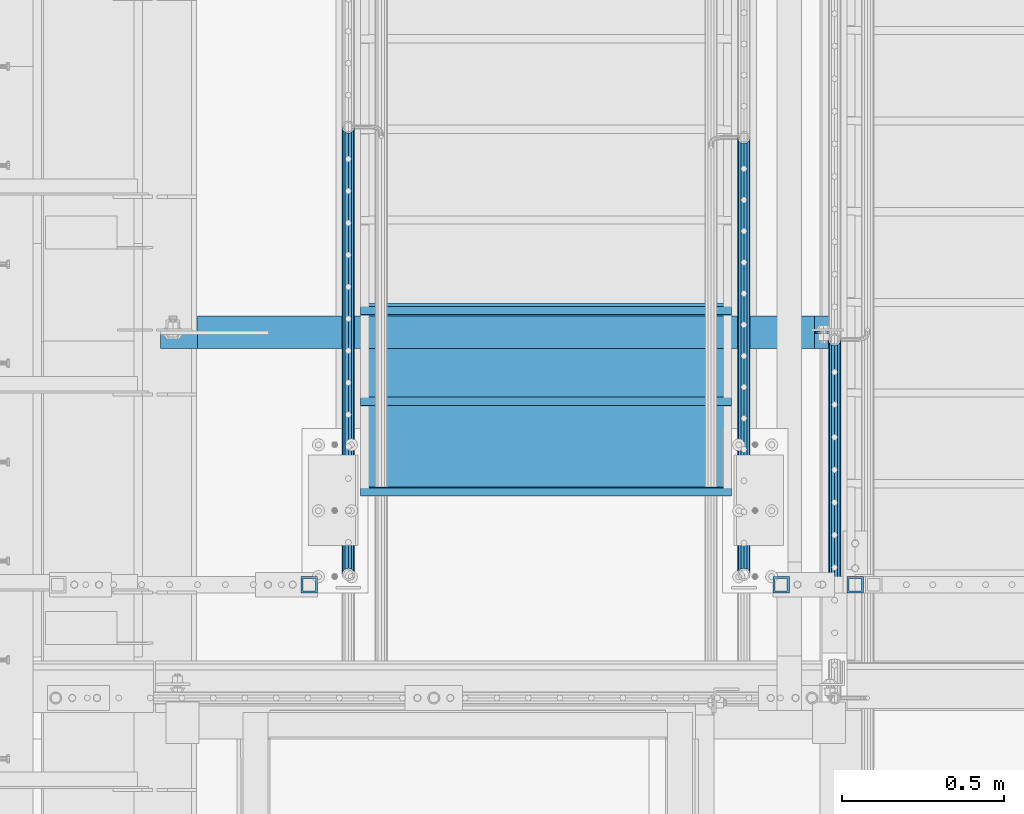
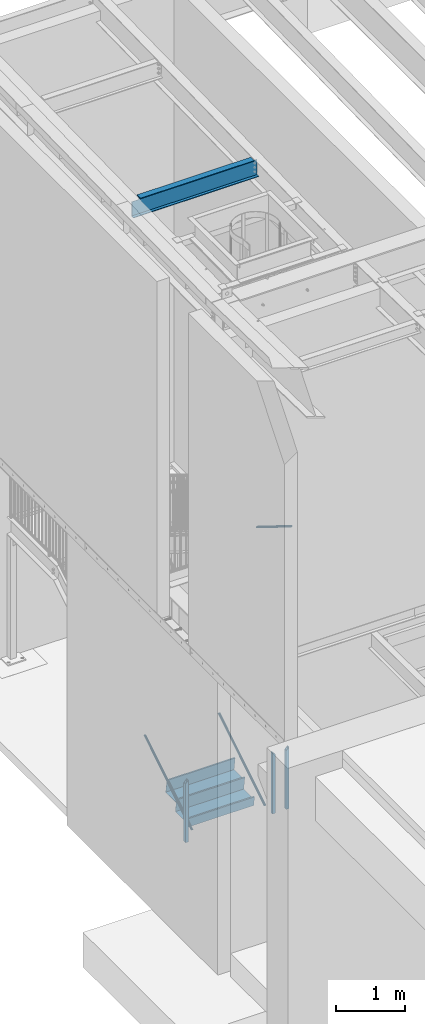
# One storey, part 1086 of 1763: 7 beams, 3 members, 7 elements without a shape of their own.
"""IFC2X3 building model written with IfcOpenShell, lengths in millimetres."""

from ifc_helpers import new_model, si_unit, frame, origin_with_axes, place, context, subcontext, project, spatial, faceted_brep, material, type_object, element, aggregate, save


model = new_model("IFC2X3")

# Units and contexts
model_context = context("Model", 3, precision=1e-05, world=origin_with_axes())
body_context = subcontext(model_context, "Body", "Model", "MODEL_VIEW")
ifc_project = project(units=[si_unit("LENGTHUNIT", "METRE", prefix="MILLI"), si_unit("AREAUNIT", "SQUARE_METRE"), si_unit("VOLUMEUNIT", "CUBIC_METRE"), si_unit("MASSUNIT", "GRAM", prefix="KILO"), si_unit("TIMEUNIT", "SECOND"), si_unit("PLANEANGLEUNIT", "RADIAN"), si_unit("SOLIDANGLEUNIT", "STERADIAN"), si_unit("THERMODYNAMICTEMPERATUREUNIT", "DEGREE_CELSIUS"), si_unit("LUMINOUSINTENSITYUNIT", "LUMEN")], contexts=[model_context])

# Site, building, storey
site_placement = place(None, origin_with_axes())
site = spatial("IfcSite", under=ifc_project, at=site_placement, CompositionType="ELEMENT")
building_placement = place(site_placement, origin_with_axes())
building = spatial("IfcBuilding", under=site, at=building_placement, Name="Undefined", CompositionType="ELEMENT")
storey_placement = place(building_placement, origin_with_axes())
storey = spatial("IfcBuildingStorey", under=building, at=storey_placement, Name="Undefined", CompositionType="ELEMENT", Elevation=0.0)

# Assembly, beam
assembly_1_placement = place(storey_placement, origin_with_axes())
assembly_1 = element("IfcElementAssembly", 1, at=assembly_1_placement, inside=storey, Name="GUARDRAIL", AssemblyPlace="NOTDEFINED", PredefinedType="RIGID_FRAME")
ifc_material_1 = material()
beam_type_1 = type_object("IfcBeamType", Name="HSS2X2X1/4", PredefinedType="NOTDEFINED")
beam_1_placement = place(assembly_1_placement, frame((-86899.1872737229, 32023.0500064728, 1371.60003013257), z_axis=(1.0, 0.0, 0.0), x_axis=(0.0, 0.0, -1.0)))
beam_1 = element("IfcBeam", 2, at=beam_1_placement, type_object=beam_type_1, material=ifc_material_1, Name="GUARDRAIL", ObjectType="HSS2X2X1/4", context=body_context, shape_type="Brep", body=[
    faceted_brep([(19.0500000000052, 19.0499999999993, -19.0500000000029), (19.0500000000052, -19.0499999999993, -19.0500000000029), (1060.45, -19.0499999999993, -19.0500000000029), (1060.45, 19.0499999999993, -19.0500000000029), (-19.0499999999993, -19.0499999999993, 19.0500000000029), (1060.45, -19.0499999999993, 19.0500000000029), (-19.0499999999993, 19.0499999999993, 19.0500000000029), (1060.45, 19.0499999999993, 19.0500000000029), (25.400000000006, 25.4000000000015, -25.3999999999942), (-25.4000000000001, 25.4000000000015, 25.3999999999942), (1060.45, 25.4000000000015, 25.3999999999942), (1060.45, 25.4000000000015, -25.3999999999942), (-25.4000000000001, -25.4000000000015, 25.3999999999942), (1060.45, -25.4000000000015, 25.3999999999942), (25.400000000006, -25.4000000000015, -25.3999999999942), (1060.45, -25.4000000000015, -25.3999999999942)], [[[0, 1, 2, 3]], [[1, 4, 5, 2]], [[4, 6, 7, 5]], [[6, 0, 3, 7]], [[8, 9, 10, 11]], [[9, 12, 13, 10]], [[12, 14, 15, 13]], [[14, 8, 11, 15]], [[13, 15, 11, 10], [5, 7, 3, 2]], [[14, 12, 9, 8], [6, 4, 1, 0]]]),
])
aggregate(assembly_1, [beam_1])

# Assembly, beams
assembly_2_placement = place(storey_placement, origin_with_axes())
assembly_2 = element("IfcElementAssembly", 3, at=assembly_2_placement, inside=storey, Name="GUARDRAIL", AssemblyPlace="NOTDEFINED", PredefinedType="RIGID_FRAME")
beam_2_placement = place(assembly_2_placement, frame((-85216.4372737343, 32023.0500064728, 1371.60003013257), z_axis=(1.0, 0.0, 0.0), x_axis=(0.0, 0.0, -1.0)))
beam_2 = element("IfcBeam", 4, at=beam_2_placement, type_object=beam_type_1, material=ifc_material_1, Name="GUARDRAIL", ObjectType="HSS2X2X1/4", context=body_context, shape_type="Brep", body=[
    faceted_brep([(19.0500000000052, 19.0499999999993, -19.0500000000029), (19.0500000000052, -19.0499999999993, -19.0500000000029), (1060.45, -19.0499999999993, -19.0500000000029), (1060.45, 19.0499999999993, -19.0500000000029), (-19.0499999999993, -19.0499999999993, 19.0500000000029), (1060.45, -19.0499999999993, 19.0500000000029), (-19.0499999999993, 19.0499999999993, 19.0500000000029), (1060.45, 19.0499999999993, 19.0500000000029), (25.400000000006, 25.4000000000015, -25.3999999999942), (-25.4000000000001, 25.4000000000015, 25.3999999999942), (1060.45, 25.4000000000015, 25.3999999999942), (1060.45, 25.4000000000015, -25.3999999999942), (-25.4000000000001, -25.4000000000015, 25.3999999999942), (1060.45, -25.4000000000015, 25.3999999999942), (25.400000000006, -25.4000000000015, -25.3999999999942), (1060.45, -25.4000000000015, -25.3999999999942)], [[[0, 1, 2, 3]], [[1, 4, 5, 2]], [[4, 6, 7, 5]], [[6, 0, 3, 7]], [[8, 9, 10, 11]], [[9, 12, 13, 10]], [[12, 14, 15, 13]], [[14, 8, 11, 15]], [[13, 15, 11, 10], [5, 7, 3, 2]], [[14, 12, 9, 8], [6, 4, 1, 0]]]),
])
beam_3_placement = place(assembly_2_placement, frame((-85445.037267589, 32023.0500064728, 1371.60003013257), z_axis=(1.0, 0.0, 0.0), x_axis=(0.0, 0.0, -1.0)))
beam_3 = element("IfcBeam", 5, at=beam_3_placement, type_object=beam_type_1, material=ifc_material_1, Name="GUARDRAIL", ObjectType="HSS2X2X1/4", context=body_context, shape_type="Brep", body=[
    faceted_brep([(-19.0500000000052, 19.0499999999993, -19.0500000000029), (-19.0500000000052, -19.0499999999993, -19.0500000000029), (1060.45, -19.0499999999993, -19.0500000000029), (1060.45, 19.0499999999993, -19.0500000000029), (19.0499999999993, -19.0499999999993, 19.0500000000029), (1060.45, -19.0499999999993, 19.0500000000029), (19.0499999999993, 19.0499999999993, 19.0500000000029), (1060.45, 19.0499999999993, 19.0500000000029), (-25.400000000006, 25.4000000000015, -25.3999999999942), (25.4000000000001, 25.4000000000015, 25.3999999999942), (1060.45, 25.4000000000015, 25.3999999999942), (1060.45, 25.4000000000015, -25.3999999999942), (25.4000000000001, -25.4000000000015, 25.3999999999942), (1060.45, -25.4000000000015, 25.3999999999942), (-25.400000000006, -25.4000000000015, -25.3999999999942), (1060.45, -25.4000000000015, -25.3999999999942)], [[[0, 1, 2, 3]], [[1, 4, 5, 2]], [[4, 6, 7, 5]], [[6, 0, 3, 7]], [[8, 9, 10, 11]], [[9, 12, 13, 10]], [[12, 14, 15, 13]], [[14, 8, 11, 15]], [[13, 15, 11, 10], [5, 7, 3, 2]], [[14, 12, 9, 8], [6, 4, 1, 0]]]),
])
aggregate(assembly_2, [beam_2, beam_3])

# Assembly, member
assembly_3_placement = place(storey_placement, origin_with_axes())
assembly_3 = element("IfcElementAssembly", 6, at=assembly_3_placement, inside=storey, Name="RAIL", AssemblyPlace="NOTDEFINED", PredefinedType="RIGID_FRAME")
ifc_material_2 = material(Name="STEEL/A513")
member_type = type_object("IfcMemberType", PredefinedType="NOTDEFINED")
member_1_placement = place(assembly_3_placement, frame((-85559.3372736933, 32054.8000003693, 449.092697030226), z_axis=(0.0, -0.527268387919125, 0.849698797869673), x_axis=(0.0, 0.849698797869672, 0.527268387919126)))
member_1 = element("IfcMember", 7, at=member_1_placement, type_object=member_type, material=ifc_material_2, Name="RAIL", context=body_context, shape_type="Brep", body=[
    faceted_brep([(1575.14754564977, -9.52499999999418, 16.4977839397434), (1572.02558643742, -9.52499999551219, 11.4667123821018), (1572.58759299681, -7.68349999999919, 13.3082123776148), (1571.44218241748, 4.36557456851006e-11, 15.3669999976591), (1573.72761518211, 2.91038304567337e-11, 19.0499999976455), (1572.58759299399, 7.68349999999919, 13.3082123776148), (1572.02558643186, 9.52500000447617, 11.4667123731379), (1575.14754564977, 9.52499999999418, 16.4977839397434), (1584.32612048254, 19.0500000000029, -2.33194441534579e-09), (1579.02686783064, 16.4977839420899, 9.52499999765496), (1567.20566387564, 16.4977839420899, -9.52500000228974), (1574.13038414392, 13.3082123799541, 7.68349999766724), (1571.78546022086, 15.3669999999984, -2.31739250011742e-09), (1564.59461295365, 13.3082123799541, -7.68350000229111), (1557.794579011, 9.52500000447617, -11.4667123777472), (1554.67261979309, 9.52499999999418, -16.4977839443527), (1556.07115280309, 7.68349999999919, -13.3082123822205), (1552.37064003676, 0.0, -15.3670000022612), (1550.08520727212, 0.0, -19.0500000022475), (1557.79457900544, -9.52499999551219, -11.4667123867112), (1554.67261979309, -9.52499999999418, -16.4977839443527), (1556.07115280592, -7.68349999999919, -13.3082123822242), (1584.32612048011, -19.0499999955209, -8.18545231595635e-10), (1567.20566387564, -16.4977839420899, -9.52500000228974), (1579.02686783064, -16.4977839420899, 9.52499999765496), (1564.59461296419, -13.3082123799541, -7.68350000229111), (1571.7854602314, -15.3669999999984, -2.31739250011742e-09), (1574.13038415446, -13.3082123799541, 7.6834999976636), (5.29925264853227, -16.4977839420899, -9.52499999999418), (9.17857482939507, -9.52499999999418, -16.497783942079), (0.0, 19.0500000000029, 0.0), (5.29925264853227, 16.4977839420899, -9.52499999999418), (17.1204566035267, 16.4977839420899, 9.5249999999578), (29.6535006860868, 9.52499999999418, 16.4977839420208), (34.240913207057, 2.60333763435483e-08, 19.0499999999156), (9.17857482939507, 9.52499999999418, -16.497783942079), (10.5985052970609, 0.0, -19.0499999999811), (12.8839380616882, 0.0, -15.3669999999911), (12.3005340283707, -9.5249999739608, -11.4667124059888), (11.7385274769949, -7.68349999999919, -13.3082123799504), (11.7385274934168, 7.68349999999919, -13.3082123799504), (12.3005340606833, 9.52500002602756, -11.466712353922), (10.1957363620568, 13.3082123799541, -7.68350000000282), (12.5406602851217, 15.3669999999984, -1.81898940354586e-11), (19.7315075523256, 13.3082123799541, 7.68349999995917), (26.5315414548058, 9.52500002602756, 11.4667123538638), (28.2549676843155, 7.68349999999919, 13.3082123798886), (31.9554804424188, 2.60333763435483e-08, 15.3669999999256), (28.2549676678937, -7.68349999999919, 13.3082123798922), (26.5315414871147, -9.5249999739608, 11.4667124059306), (29.6535006860868, -9.52499999999418, 16.4977839420208), (17.1204566035267, -16.4977839420899, 9.5249999999578), (0.0, -19.0500000000029, 0.0), (19.7315074910439, -13.3082123799541, 7.68349999995917), (12.5406602238363, -15.3669999999984, -1.81898940354586e-11), (10.195736300775, -13.3082123799541, -7.68349999999919)], [[[0, 1, 2, 3, 4]], [[4, 3, 5, 6, 7]], [[8, 9, 10]], [[7, 6, 11, 12, 13, 14, 15, 10, 9]], [[16, 17, 18, 15, 14]], [[19, 20, 18, 17, 21]], [[22, 23, 24]], [[24, 23, 20, 19, 25, 26, 27, 1, 0]], [[28, 29, 20, 23]], [[30, 31, 32]], [[33, 34, 4, 7]], [[32, 33, 7, 9]], [[30, 32, 9, 8]], [[31, 30, 8, 10]], [[35, 31, 10, 15]], [[36, 35, 15, 18]], [[29, 36, 18, 20]], [[37, 36, 29, 38, 39]], [[40, 41, 35, 36, 37]], [[32, 31, 35, 41, 42, 43, 44, 45, 33]], [[33, 45, 46, 47, 34]], [[34, 47, 48, 49, 50]], [[34, 50, 0, 4]], [[50, 51, 24, 0]], [[51, 52, 22, 24]], [[52, 28, 23, 22]], [[51, 28, 52]], [[50, 49, 53, 54, 55, 38, 29, 28, 51]], [[54, 53, 27, 26]], [[55, 54, 26, 25]], [[21, 39, 38, 55, 25, 19]], [[37, 39, 21, 17]], [[40, 37, 17, 16]], [[42, 41, 40, 16, 14, 13]], [[43, 42, 13, 12]], [[44, 43, 12, 11]], [[5, 46, 45, 44, 11, 6]], [[47, 46, 5, 3]], [[48, 47, 3, 2]], [[53, 49, 48, 2, 1, 27]]]),
])
aggregate(assembly_3, [member_1])

assembly_4_placement = place(storey_placement, origin_with_axes())
assembly_4 = element("IfcElementAssembly", 8, at=assembly_4_placement, inside=storey, Name="RAIL", AssemblyPlace="NOTDEFINED", PredefinedType="RIGID_FRAME")
member_2_placement = place(assembly_4_placement, frame((-86778.5372736929, 32054.8000003693, 449.092697025802), z_axis=(0.0, -0.527268387919125, 0.849698797869673), x_axis=(0.0, 0.849698797869672, 0.527268387919126)))
member_2 = element("IfcMember", 9, at=member_2_placement, type_object=member_type, material=ifc_material_2, Name="RAIL", context=body_context, shape_type="Brep", body=[
    faceted_brep([(1613.01194349174, -9.52499999999418, 16.4977839396925), (1609.88998428405, -9.5249999880034, 11.4667123895597), (1610.45199084115, -7.68349999999919, 13.3082123775639), (1609.30658025945, 1.01863406598568e-10, 15.3669999976082), (1611.59201302408, 7.27595761418343e-11, 19.0499999975946), (1610.45199083359, 7.68349999999919, 13.3082123775639), (1609.88998426917, 9.52500001198496, 11.4667123655781), (1613.01194349174, 9.52499999999418, 16.4977839396925), (1622.19051832688, 19.0500000000029, -2.38651409745216e-09), (1616.89126567261, 16.4977839420899, 9.52499999760767), (1605.07006171762, 16.4977839420899, -9.52500000234431), (1611.99478197705, 13.3082123799541, 7.68349999761631), (1609.64985805399, 15.3669999999984, -2.36468622460961e-09), (1602.45901078678, 13.3082123799541, -7.68350000234204), (1595.65897685763, 9.52500001198496, -11.4667123702893), (1592.53701763506, 9.52499999999418, -16.4977839444036), (1593.93555064269, 7.68349999999919, -13.3082123822751), (1590.23503787873, 0.0, -15.3670000023085), (1587.9496051141, 0.0, -19.0500000023021), (1595.65897684274, -9.5249999880034, -11.4667123942709), (1592.53701763506, -9.52499999999418, -16.4977839444036), (1593.93555065026, -7.68349999999919, -13.3082123822751), (1622.19051832273, -19.0499999880121, 1.89174897968769e-10), (1605.07006171762, -16.4977839420899, -9.52500000234431), (1616.89126567261, -16.4977839420899, 9.52499999760767), (1602.459010815, -13.3082123799541, -7.68350000234204), (1609.6498580822, -15.3669999999984, -2.36832420341671e-09), (1611.99478200527, -13.3082123799541, 7.68349999761631), (5.29925264853227, -16.4977839420899, -9.52499999999418), (9.17857482939507, -9.52499999999418, -16.497783942079), (0.0, 19.0500000000029, 0.0), (5.29925264853227, 16.4977839420899, -9.52499999999418), (17.1204566035267, 16.4977839420899, 9.5249999999578), (29.6535006860868, 9.52499999999418, 16.4977839420208), (34.240913207057, 2.60333763435483e-08, 19.0499999999156), (9.17857482939507, 9.52499999999418, -16.497783942079), (10.5985052970609, 0.0, -19.0499999999811), (12.8839380616882, 0.0, -15.3669999999911), (12.3005340283707, -9.5249999739608, -11.4667124059888), (11.7385274769949, -7.68349999999919, -13.3082123799504), (11.7385274934168, 7.68349999999919, -13.3082123799504), (12.3005340606833, 9.52500002602756, -11.466712353922), (10.1957363620568, 13.3082123799541, -7.68350000000282), (12.5406602851217, 15.3669999999984, -1.81898940354586e-11), (19.7315075523256, 13.3082123799541, 7.68349999995917), (26.5315414548058, 9.52500002602756, 11.4667123538638), (28.2549676843155, 7.68349999999919, 13.3082123798886), (31.9554804424188, 2.60333763435483e-08, 15.3669999999256), (28.2549676678937, -7.68349999999919, 13.3082123798922), (26.5315414871147, -9.5249999739608, 11.4667124059306), (29.6535006860868, -9.52499999999418, 16.4977839420208), (17.1204566035267, -16.4977839420899, 9.5249999999578), (0.0, -19.0500000000029, 0.0), (19.7315074910439, -13.3082123799541, 7.68349999995917), (12.5406602238363, -15.3669999999984, -1.81898940354586e-11), (10.195736300775, -13.3082123799541, -7.68349999999919)], [[[0, 1, 2, 3, 4]], [[4, 3, 5, 6, 7]], [[8, 9, 10]], [[7, 6, 11, 12, 13, 14, 15, 10, 9]], [[16, 17, 18, 15, 14]], [[19, 20, 18, 17, 21]], [[22, 23, 24]], [[24, 23, 20, 19, 25, 26, 27, 1, 0]], [[28, 29, 20, 23]], [[30, 31, 32]], [[33, 34, 4, 7]], [[32, 33, 7, 9]], [[30, 32, 9, 8]], [[31, 30, 8, 10]], [[35, 31, 10, 15]], [[36, 35, 15, 18]], [[29, 36, 18, 20]], [[37, 36, 29, 38, 39]], [[40, 41, 35, 36, 37]], [[32, 31, 35, 41, 42, 43, 44, 45, 33]], [[33, 45, 46, 47, 34]], [[34, 47, 48, 49, 50]], [[34, 50, 0, 4]], [[50, 51, 24, 0]], [[51, 52, 22, 24]], [[52, 28, 23, 22]], [[51, 28, 52]], [[50, 49, 53, 54, 55, 38, 29, 28, 51]], [[54, 53, 27, 26]], [[55, 54, 26, 25]], [[21, 39, 38, 55, 25, 19]], [[37, 39, 21, 17]], [[40, 37, 17, 16]], [[42, 41, 40, 16, 14, 13]], [[43, 42, 13, 12]], [[44, 43, 12, 11]], [[5, 46, 45, 44, 11, 6]], [[47, 46, 5, 3]], [[48, 47, 3, 2]], [[53, 49, 48, 2, 1, 27]]]),
])
aggregate(assembly_4, [member_2])

assembly_5_placement = place(storey_placement, origin_with_axes())
assembly_5 = element("IfcElementAssembly", 10, at=assembly_5_placement, inside=storey, Name="RAIL", AssemblyPlace="NOTDEFINED", PredefinedType="RIGID_FRAME")
member_3_placement = place(assembly_5_placement, frame((-85279.8721005617, 32778.6999998061, 4839.65249932518), z_axis=(0.0, 0.527450977296466, 0.849585467477524), x_axis=(0.0, -0.849585467029397, 0.527450978018281)))
member_3 = element("IfcMember", 11, at=member_3_placement, type_object=member_type, material=ifc_material_2, Name="RAIL", context=body_context, shape_type="Brep", body=[
    faceted_brep([(0.0, 19.0500000000029, 0.0), (5.29791245489469, 16.4977839420899, -9.52499999998327), (17.1247874453111, 16.4977839420899, 9.52499999999054), (17.1247874453111, -16.4977839420899, 9.52499999999054), (5.29791245489469, -16.4977839420899, -9.52499999998327), (0.0, -19.0500000000029, 0.0), (29.6610019340442, -9.52499999999418, 16.4977839420753), (26.5375450165775, -9.5249999868538, 11.4667123930885), (19.7357908810409, -13.3082123799541, 7.68349999999555), (12.5423330853882, -15.3669999999984, 3.63797880709171e-12), (10.195445055484, -13.3082123799541, -7.68349999998463), (12.2997104733658, -9.5249999868538, -11.466712393074), (9.17625355589189, -9.52499999999418, -16.4977839420644), (12.8823540882113, 0.0, -15.3669999999693), (10.5958249233954, 0.0, -19.0499999999665), (11.7372331812621, -7.68349999999919, -13.3082123799286), (11.7372331895313, 7.68349999999919, -13.3082123799286), (12.2997104896785, 9.52500001313456, -11.4667123667932), (9.17625355589189, 9.52499999999418, -16.4977839420644), (10.1954450863705, 13.3082123799541, -7.683499999981), (12.542333116282, 15.3669999999984, 7.27595761418343e-12), (19.735790911931, 13.3082123799541, 7.68349999999555), (26.5375450002612, 9.52500001313456, 11.4667123668078), (29.6610019340442, 9.52499999999418, 16.4977839420753), (28.2615968811733, 7.68349999999919, 13.3082123799431), (31.9630457394014, 1.31403794512153e-08, 15.3669999999838), (34.2495749042173, 1.31403794512153e-08, 19.0499999999811), (28.2615968729006, -7.68349999999919, 13.3082123799431), (1165.98039826308, -19.0500000000029, 3.38332029059529e-10), (1168.69666666842, -16.4977839420899, 9.52500000032524), (1170.68511314811, -9.52499999999418, 16.4977839424064), (1171.41293507375, 0.0, 19.0500000003121), (1161.27568337805, -9.52499999999418, -16.4977839417297), (1163.26412985775, -16.4977839420899, -9.52499999964493), (1160.54786145242, 0.0, -19.0499999996355), (1161.27568337805, 9.52499999999418, -16.4977839417297), (1163.26412985775, 16.4977839420899, -9.52499999964493), (1165.98039826308, 19.0500000000029, 3.38332029059529e-10), (1168.69666666842, 16.4977839420899, 9.52500000032524), (1170.68511314811, 9.52499999999418, 16.4977839424064), (1169.77553493701, -7.68349999999919, 13.3082123802742), (1170.36264462368, 0.0, 15.3670000003149), (1169.77553493701, 7.68349999999919, 13.3082123802742), (1168.17152144339, 13.3082123799541, 7.6835000003266), (1165.98039826308, 15.3669999999984, 3.38332029059529e-10), (1163.78927508278, 13.3082123799541, -7.68349999964994), (1162.18526158916, 7.68349999999919, -13.3082123795975), (1161.59815190248, 0.0, -15.3669999996382), (1162.18526158916, -7.68349999999919, -13.3082123795975), (1163.78927508278, -13.3082123799541, -7.68349999964994), (1165.98039826308, -15.3669999999984, 3.38332029059529e-10), (1168.17152144339, -13.3082123799541, 7.6835000003266)], [[[0, 1, 2]], [[3, 4, 5]], [[6, 7, 8, 9, 10, 11, 12, 4, 3]], [[13, 14, 12, 11, 15]], [[16, 17, 18, 14, 13]], [[2, 1, 18, 17, 19, 20, 21, 22, 23]], [[23, 22, 24, 25, 26]], [[26, 25, 27, 7, 6]], [[28, 29, 3, 5]], [[29, 30, 6, 3]], [[30, 31, 26, 6]], [[32, 33, 4, 12]], [[34, 32, 12, 14]], [[35, 34, 14, 18]], [[36, 35, 18, 1]], [[37, 36, 1, 0]], [[38, 37, 0, 2]], [[39, 38, 2, 23]], [[31, 39, 23, 26]], [[33, 28, 5, 4]], [[32, 34, 35, 36, 37, 38, 39, 31, 30, 29, 28, 33], [40, 41, 42, 43, 44, 45, 46, 47, 48, 49, 50, 51]], [[42, 41, 25, 24]], [[21, 43, 42, 24, 22]], [[44, 43, 21, 20]], [[45, 44, 20, 19]], [[46, 45, 19, 17, 16]], [[47, 46, 16, 13]], [[48, 47, 13, 15]], [[49, 48, 15, 11, 10]], [[50, 49, 10, 9]], [[51, 50, 9, 8]], [[40, 51, 8, 7, 27]], [[41, 40, 27, 25]]]),
])
aggregate(assembly_5, [member_3])

# Assembly, beams
assembly_6_placement = place(storey_placement, origin_with_axes())
assembly_6 = element("IfcElementAssembly", 12, at=assembly_6_placement, inside=storey, Name="STRINGER", AssemblyPlace="NOTDEFINED", PredefinedType="RIGID_FRAME")
ifc_material_3 = material(Name="STEEL/A36")
beam_type_2 = type_object("IfcBeamType", PredefinedType="NOTDEFINED")
beam_4_placement = place(assembly_6_placement, frame((-86168.9372737343, 32321.4999999881, 476.590178571657), z_axis=(1.0, 0.0, 0.0), x_axis=(0.0, -1.0, 0.0)))
beam_4 = element("IfcBeam", 13, at=beam_4_placement, type_object=beam_type_2, material=ifc_material_3, Name="TREAD", context=body_context, shape_type="Brep", body=[
    faceted_brep([(0.0, -1.58749999999964, -571.5), (0.0, -1.58749999999964, 571.5), (0.0, 1.58749999999964, 571.5), (0.0, 1.58749999999964, -571.5), (21.7259680928437, 1.58749999999998, 571.5), (21.7259680928437, 1.58749999999998, -571.5), (25.3999996185303, -1.58749999999998, -571.5), (25.3999996185303, -1.58749999999998, 571.5), (-2.22101164552441, 165.04701380614, 571.5), (-2.22101164552441, 165.04701380614, -571.5), (0.920455396175385, 165.507241821289, 571.5), (0.920455396175385, 165.507241821289, -571.5)], [[[0, 1, 2, 3]], [[3, 2, 4, 5]], [[1, 0, 6, 7]], [[5, 4, 8, 9]], [[4, 2, 1, 7, 10, 8]], [[7, 6, 11, 10]], [[6, 0, 3, 5, 9, 11]], [[10, 11, 9, 8]]]),
])
beam_type_3 = type_object("IfcBeamType", PredefinedType="NOTDEFINED")
beam_5_placement = place(assembly_6_placement, frame((-86168.937273734, 32880.299999984, 823.345535714862), z_axis=(1.0, 0.0, 0.0), x_axis=(0.0, -1.0, 0.0)))
beam_5 = element("IfcBeam", 14, at=beam_5_placement, type_object=beam_type_3, material=ifc_material_3, Name="TREAD", context=body_context, shape_type="Brep", body=[
    faceted_brep([(0.0, -1.58749999999964, -571.5), (0.0, -1.58749999999964, 571.5), (0.0, 1.58749999999964, 571.5), (0.0, 1.58749999999964, -571.5), (21.7259680928437, 1.58749999999998, 571.5), (21.7259680928437, 1.58749999999998, -571.5), (25.3999996185303, -1.58749999999998, -571.5), (25.3999996185303, -1.58749999999998, 571.5), (-11.1162812923722, 225.765173339844, 571.5), (-11.1162812923722, 225.765173339844, -571.5), (-7.44224977493286, 222.590173339844, -571.5), (-7.44224977493286, 222.590173339844, 571.5), (293.683722205024, 225.765173339844, 571.5), (293.683722205024, 225.765173339844, -571.5), (290.939971923828, 222.590173339844, -571.5), (290.939971923828, 222.590173339844, 571.5), (299.604174562657, 185.35280002685, 571.5), (299.604174562657, 185.35280002685, -571.5), (296.462707519531, 184.892572021484, 571.5), (296.462707519531, 184.892572021484, -571.5)], [[[0, 1, 2, 3]], [[3, 2, 4, 5]], [[1, 0, 6, 7]], [[5, 4, 8, 9]], [[7, 6, 10, 11]], [[9, 8, 12, 13]], [[11, 10, 14, 15]], [[13, 12, 16, 17]], [[12, 8, 4, 2, 1, 7, 11, 15, 18, 16]], [[15, 14, 19, 18]], [[14, 10, 6, 0, 3, 5, 9, 13, 17, 19]], [[18, 19, 17, 16]]]),
])
beam_6_placement = place(assembly_6_placement, frame((-86168.937273734, 32600.899999984, 649.967857143365), z_axis=(1.0, 0.0, 0.0), x_axis=(0.0, -1.0, 0.0)))
beam_6 = element("IfcBeam", 15, at=beam_6_placement, type_object=beam_type_3, material=ifc_material_3, Name="TREAD", context=body_context, shape_type="Brep", body=[
    faceted_brep([(0.0, -1.58749999999964, -571.5), (0.0, -1.58749999999964, 571.5), (0.0, 1.58749999999964, 571.5), (0.0, 1.58749999999964, -571.5), (21.7259680928437, 1.58749999999998, 571.5), (21.7259680928437, 1.58749999999998, -571.5), (25.3999996185303, -1.58749999999998, -571.5), (25.3999996185303, -1.58749999999998, 571.5), (-11.1162812923722, 225.765173339844, 571.5), (-11.1162812923722, 225.765173339844, -571.5), (-7.44224977493286, 222.590173339844, -571.5), (-7.44224977493286, 222.590173339844, 571.5), (293.683722205024, 225.765173339844, 571.5), (293.683722205024, 225.765173339844, -571.5), (290.939971923828, 222.590173339844, -571.5), (290.939971923828, 222.590173339844, 571.5), (299.604174562657, 185.35280002685, 571.5), (299.604174562657, 185.35280002685, -571.5), (296.462707519531, 184.892572021484, 571.5), (296.462707519531, 184.892572021484, -571.5)], [[[0, 1, 2, 3]], [[3, 2, 4, 5]], [[1, 0, 6, 7]], [[5, 4, 8, 9]], [[7, 6, 10, 11]], [[9, 8, 12, 13]], [[11, 10, 14, 15]], [[13, 12, 16, 17]], [[12, 8, 4, 2, 1, 7, 11, 15, 18, 16]], [[15, 14, 19, 18]], [[14, 10, 6, 0, 3, 5, 9, 13, 17, 19]], [[18, 19, 17, 16]]]),
])
aggregate(assembly_6, [beam_4, beam_5, beam_6])

# Assembly, beam
assembly_7_placement = place(storey_placement, origin_with_axes())
assembly_7 = element("IfcElementAssembly", 16, at=assembly_7_placement, inside=storey, Name="BEAM", AssemblyPlace="NOTDEFINED", PredefinedType="RIGID_FRAME")
ifc_material_4 = material(Name="STEEL/A992")
beam_type_4 = type_object("IfcBeamType", Name="W12X22", PredefinedType="NOTDEFINED")
beam_7_placement = place(assembly_7_placement, frame((-87375.4372736983, 32800.925, 11192.2034472341), z_axis=(0.0, 0.0, 1.0), x_axis=(1.0, 0.0, 0.0)))
beam_7 = element("IfcBeam", 17, at=beam_7_placement, type_object=beam_type_4, material=ifc_material_4, Name="BEAM", ObjectType="W12X22", context=body_context, shape_type="Brep", body=[
    faceted_brep([(18.2562499999913, -3.17499999999927, -144.4625), (18.2562499999913, -50.7999999999993, -144.4625), (2109.67410714286, -50.7999999999993, -144.4625), (2109.67410714286, -3.17499999999927, -144.4625), (18.2562499999913, -50.7999999999993, -155.575000000001), (2109.67410714286, -50.7999999999993, -155.575000000001), (2109.67410714286, 3.17499999999927, -144.4625), (2109.67410714286, 50.7999999999993, -144.4625), (132.556249999994, 50.7999999999993, -144.4625), (132.556249999994, 3.17575008238782, -144.4625), (2033.47410714286, -50.7999999999993, 155.575000000001), (2033.47410714286, -50.7999999999993, 144.4625), (2033.47410714286, -3.17499999999927, 144.4625), (2033.47410714286, -3.17499999999927, 136.265001487105), (2033.47410714286, 3.17499999999927, 136.265001487105), (2033.47410714286, 3.17499999999927, 144.4625), (2033.47410714286, 50.7999999999993, 144.4625), (2033.47410714286, 50.7999999999993, 155.575000000001), (2034.44083706544, -3.17499999999927, 131.404921969059), (2034.44083706544, 3.17499999999927, 131.404921969059), (2037.19385096592, -3.17499999999927, 127.284745500905), (2037.19385096592, 3.17499999999927, 127.284745500905), (2041.31402743408, -3.17499999999927, 124.531731600428), (2041.31402743408, 3.17499999999927, 124.531731600428), (2046.17410695212, -3.17499999999927, 123.56500167784), (2046.17410695212, 3.17499999999927, 123.56500167784), (2109.67410714286, -3.17499999999927, 123.56500167784), (2109.67410714286, 3.17499999999927, 123.56500167784), (2109.67410714286, 50.7999999999993, -155.575000000001), (132.556249999994, 50.7999999999993, -155.575000000001), (132.556249999994, 3.17575008238782, -155.575000000001), (18.2562499999913, 3.17575008238782, -155.575000000001), (18.2562499999913, 3.17499999999927, -144.4625), (124.716329708754, -3.17499999999927, 105.741729925645), (124.716329708754, 3.17500736736474, 105.741729925645), (119.856250190714, 3.1750086254724, 104.775000003057), (119.856250190714, -3.17499999999927, 104.775000003057), (128.836506176915, -3.17499999999927, 108.494743826122), (128.836506176915, 3.17500378457771, 108.494743826122), (131.589520077396, -3.17499999999927, 112.614920294276), (131.589520077396, 3.17499842256075, 112.614920294276), (132.55624999998, -3.17499999999927, 117.474999812322), (132.55624999998, 3.17499209762536, 117.474999812322), (18.2562499999913, 3.17499999999927, -137.353076309833), (18.2562499999913, 3.17499999999927, 104.775000003057), (132.55624999998, 3.17499999999927, 144.4625), (132.55624999998, 50.7999999999993, 144.4625), (132.55624999998, 50.7999999999993, 155.575000000001), (132.55624999998, -50.7999999999993, 155.575000000001), (132.55624999998, -50.7999999999993, 144.4625), (132.55624999998, -3.17499999999927, 144.4625), (18.2562499999913, -3.17499999999927, 104.775000003057)], [[[0, 1, 2, 3]], [[1, 4, 5, 2]], [[6, 7, 8, 9]], [[10, 11, 12, 13, 14, 15, 16, 17]], [[18, 19, 14, 13]], [[20, 21, 19, 18]], [[22, 23, 21, 20]], [[24, 25, 23, 22]], [[26, 27, 25, 24]], [[3, 2, 5, 28, 7, 6, 27, 26]], [[7, 28, 29, 8]], [[8, 29, 30, 9]], [[28, 5, 4, 31, 30, 29]], [[9, 30, 31, 32]], [[33, 34, 35, 36]], [[37, 38, 34, 33]], [[39, 40, 38, 37]], [[41, 42, 40, 39]], [[15, 14, 19, 21, 23, 25, 27, 6, 9, 32, 43, 44, 35, 34, 38, 40, 42, 45]], [[16, 15, 45, 46]], [[17, 16, 46, 47]], [[10, 17, 47, 48]], [[11, 10, 48, 49]], [[12, 11, 49, 50]], [[48, 47, 46, 45, 42, 41, 50, 49]], [[39, 37, 33, 36, 51, 0, 3, 26, 24, 22, 20, 18, 13, 12, 50, 41]], [[43, 32, 31, 4, 1, 0, 51, 44]], [[36, 35, 44, 51]]]),
])
aggregate(assembly_7, [beam_7])

save(model, "model.ifc")
